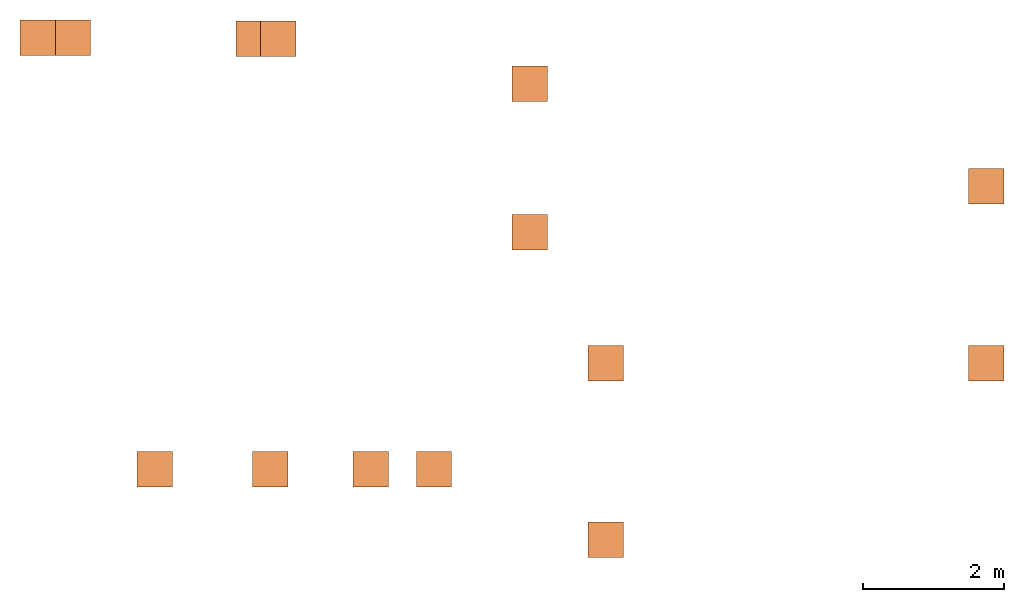
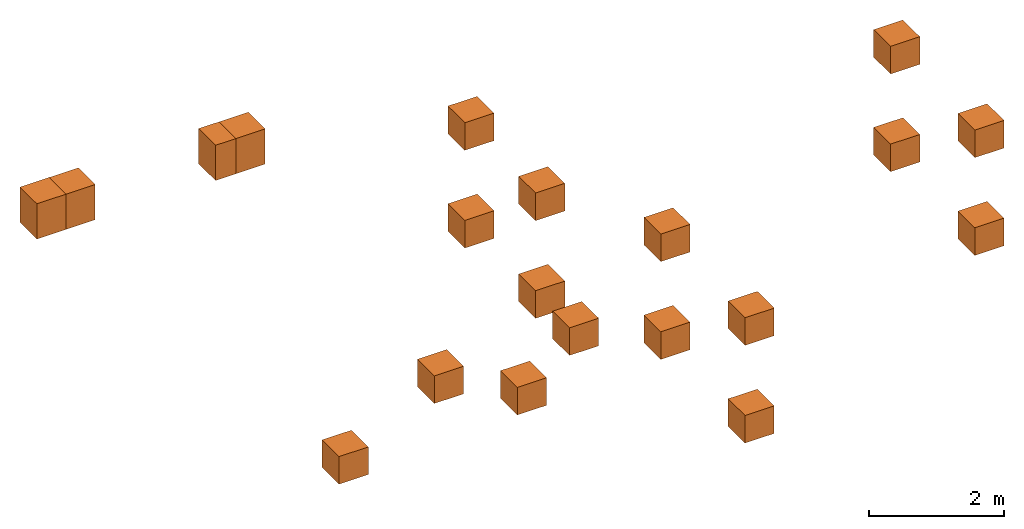
# One storey: 20 proxies.
"""IFC2X3 building model written with IfcOpenShell, lengths in metres."""

from ifc_helpers import new_model, entity, si_unit, converted_unit, frame, origin, place, context, subcontext, project, spatial, faceted_brep, material, element, save


model = new_model("IFC2X3")

# Units and contexts
model_context = context("Model", 3, precision=1e-05, world=origin())
body_context = subcontext(model_context, "Body", "Model", "MODEL_VIEW")
ifc_project = project(units=[si_unit("LENGTHUNIT", "METRE"), si_unit("AREAUNIT", "SQUARE_METRE"), si_unit("VOLUMEUNIT", "CUBIC_METRE"), converted_unit("PLANEANGLEUNIT", "DEGREE", entity("IfcPlaneAngleMeasure", 0.0174532925199433), si_unit("PLANEANGLEUNIT", "RADIAN"), dimensions=[0, 0, 0, 0, 0, 0, 0])], contexts=[model_context])

# Site, building, storey
site_placement = place(None, frame((2.0, 7.0, 6.0)))
site = spatial("IfcSite", under=ifc_project, at=site_placement, CompositionType="ELEMENT")
building_placement = place(site_placement, origin())
building = spatial("IfcBuilding", under=site, at=building_placement, Name="de", CompositionType="ELEMENT")
storey_placement = place(building_placement, frame((0.0, 0.0, 4.0)))
storey = spatial("IfcBuildingStorey", under=building, at=storey_placement, CompositionType="ELEMENT", Elevation=4.0)

# Proxies
ifc_material_1 = material()
proxy_1_placement = place(storey_placement, frame((-5.857044050769239, 7.518461170358987, 3.07)))
element("IfcBuildingElementProxy", 1, at=proxy_1_placement, inside=storey, material=ifc_material_1, context=body_context, shape_type="Brep", body=[
    faceted_brep([(0.0, 0.0, 0.0), (0.5, 0.0, 0.0), (0.5, 0.5, 0.0), (0.0, 0.5, 0.0), (0.5, 0.0, 0.6382133161913789), (0.0, 0.0, 0.6382133161913789), (0.0, 0.5, 0.6382133161913789), (0.5, 0.5, 0.6382133161913789), (0.5, 0.0, 0.0), (0.0, 0.0, 0.0), (0.0, 0.0, 0.6382133161913789), (0.5, 0.0, 0.6382133161913789), (0.5, 0.5, 0.0), (0.5, 0.0, 0.0), (0.5, 0.0, 0.6382133161913789), (0.5, 0.5, 0.6382133161913789), (0.0, 0.5, 0.0), (0.5, 0.5, 0.0), (0.5, 0.5, 0.6382133161913789), (0.0, 0.5, 0.6382133161913789), (0.0, 0.0, 0.0), (0.0, 0.5, 0.0), (0.0, 0.5, 0.6382133161913789), (0.0, 0.0, 0.6382133161913789)], [[[0, 1, 2, 3]], [[4, 5, 6, 7]], [[8, 9, 10, 11]], [[12, 13, 14, 15]], [[16, 17, 18, 19]], [[20, 21, 22, 23]]], orient=[[False], [False], [False], [False], [False], [False]]),
])
ifc_material_2 = material()
proxy_2_placement = place(storey_placement, frame((-5.357044050769239, 7.518461170358987, 3.07)))
element("IfcBuildingElementProxy", 2, at=proxy_2_placement, inside=storey, material=ifc_material_2, context=body_context, shape_type="Brep", body=[
    faceted_brep([(0.0, 0.0, 0.0), (0.5, 0.0, 0.0), (0.5, 0.5, 0.0), (0.0, 0.5, 0.0), (0.5, 0.0, 0.6382133161913789), (0.0, 0.0, 0.6382133161913789), (0.0, 0.5, 0.6382133161913789), (0.5, 0.5, 0.6382133161913789), (0.5, 0.0, 0.0), (0.0, 0.0, 0.0), (0.0, 0.0, 0.6382133161913789), (0.5, 0.0, 0.6382133161913789), (0.5, 0.5, 0.0), (0.5, 0.0, 0.0), (0.5, 0.0, 0.6382133161913789), (0.5, 0.5, 0.6382133161913789), (0.0, 0.5, 0.0), (0.5, 0.5, 0.0), (0.5, 0.5, 0.6382133161913789), (0.0, 0.5, 0.6382133161913789), (0.0, 0.0, 0.0), (0.0, 0.5, 0.0), (0.0, 0.5, 0.6382133161913789), (0.0, 0.0, 0.6382133161913789)], [[[0, 1, 2, 3]], [[4, 5, 6, 7]], [[8, 9, 10, 11]], [[12, 13, 14, 15]], [[16, 17, 18, 19]], [[20, 21, 22, 23]]], orient=[[False], [False], [False], [False], [False], [False]]),
])
ifc_material_3 = material()
proxy_3_placement = place(storey_placement, frame((-2.803355565197468, 7.504048402584867, 3.07)))
element("IfcBuildingElementProxy", 3, at=proxy_3_placement, inside=storey, material=ifc_material_3, context=body_context, shape_type="Brep", body=[
    faceted_brep([(0.0, 0.0, 0.0), (0.5, 0.0, 0.0), (0.5, 0.5, 0.0), (0.0, 0.5, 0.0), (0.5, 0.0, 0.6382133161913789), (0.0, 0.0, 0.6382133161913789), (0.0, 0.5, 0.6382133161913789), (0.5, 0.5, 0.6382133161913789), (0.5, 0.0, 0.0), (0.0, 0.0, 0.0), (0.0, 0.0, 0.6382133161913789), (0.5, 0.0, 0.6382133161913789), (0.5, 0.5, 0.0), (0.5, 0.0, 0.0), (0.5, 0.0, 0.6382133161913789), (0.5, 0.5, 0.6382133161913789), (0.0, 0.5, 0.0), (0.5, 0.5, 0.0), (0.5, 0.5, 0.6382133161913789), (0.0, 0.5, 0.6382133161913789), (0.0, 0.0, 0.0), (0.0, 0.5, 0.0), (0.0, 0.5, 0.6382133161913789), (0.0, 0.0, 0.6382133161913789)], [[[0, 1, 2, 3]], [[4, 5, 6, 7]], [[8, 9, 10, 11]], [[12, 13, 14, 15]], [[16, 17, 18, 19]], [[20, 21, 22, 23]]], orient=[[False], [False], [False], [False], [False], [False]]),
])
ifc_material_4 = material()
proxy_4_placement = place(storey_placement, frame((-2.454882605736548, 7.504048402584867, 3.07)))
element("IfcBuildingElementProxy", 4, at=proxy_4_placement, inside=storey, material=ifc_material_4, context=body_context, shape_type="Brep", body=[
    faceted_brep([(0.0, 0.0, 0.0), (0.5, 0.0, 0.0), (0.5, 0.5, 0.0), (0.0, 0.5, 0.0), (0.5, 0.0, 0.6382133161913789), (0.0, 0.0, 0.6382133161913789), (0.0, 0.5, 0.6382133161913789), (0.5, 0.5, 0.6382133161913789), (0.5, 0.0, 0.0), (0.0, 0.0, 0.0), (0.0, 0.0, 0.6382133161913789), (0.5, 0.0, 0.6382133161913789), (0.5, 0.5, 0.0), (0.5, 0.0, 0.0), (0.5, 0.0, 0.6382133161913789), (0.5, 0.5, 0.6382133161913789), (0.0, 0.5, 0.0), (0.5, 0.5, 0.0), (0.5, 0.5, 0.6382133161913789), (0.0, 0.5, 0.6382133161913789), (0.0, 0.0, 0.0), (0.0, 0.5, 0.0), (0.0, 0.5, 0.6382133161913789), (0.0, 0.0, 0.6382133161913789)], [[[0, 1, 2, 3]], [[4, 5, 6, 7]], [[8, 9, 10, 11]], [[12, 13, 14, 15]], [[16, 17, 18, 19]], [[20, 21, 22, 23]]], orient=[[False], [False], [False], [False], [False], [False]]),
])
ifc_material_5 = material()
proxy_5_placement = place(storey_placement, frame((-4.2015625, 1.416979166666668, 1.75)))
element("IfcBuildingElementProxy", 5, at=proxy_5_placement, inside=storey, material=ifc_material_5, context=body_context, shape_type="Brep", body=[
    faceted_brep([(0.0, 0.5, 0.0), (0.5, 0.5, 0.0), (0.5, 0.5, 0.5), (0.0, 0.5, 0.5), (0.5, 0.0, 0.0), (0.0, 0.0, 0.0), (0.0, 0.0, 0.5), (0.5, 0.0, 0.5), (0.5, 0.5, 0.0), (0.0, 0.5, 0.0), (0.0, 0.0, 0.0), (0.5, 0.0, 0.0), (0.5, 0.5, 0.5), (0.5, 0.5, 0.0), (0.5, 0.0, 0.0), (0.5, 0.0, 0.5), (0.0, 0.5, 0.5), (0.5, 0.5, 0.5), (0.5, 0.0, 0.5), (0.0, 0.0, 0.5), (0.0, 0.5, 0.0), (0.0, 0.5, 0.5), (0.0, 0.0, 0.5), (0.0, 0.0, 0.0)], [[[0, 1, 2, 3]], [[4, 5, 6, 7]], [[8, 9, 10, 11]], [[12, 13, 14, 15]], [[16, 17, 18, 19]], [[20, 21, 22, 23]]], orient=[[False], [False], [False], [False], [False], [False]]),
])
ifc_material_6 = material()
proxy_6_placement = place(storey_placement, frame((-1.147874014428229, 1.416979166666668, 1.934412767774121)))
element("IfcBuildingElementProxy", 6, at=proxy_6_placement, inside=storey, material=ifc_material_6, context=body_context, shape_type="Brep", body=[
    faceted_brep([(0.0, 0.5, 0.0), (0.5, 0.5, 0.0), (0.5, 0.5, 0.5), (0.0, 0.5, 0.5), (0.5, 0.0, 0.0), (0.0, 0.0, 0.0), (0.0, 0.0, 0.5), (0.5, 0.0, 0.5), (0.5, 0.5, 0.0), (0.0, 0.5, 0.0), (0.0, 0.0, 0.0), (0.5, 0.0, 0.0), (0.5, 0.5, 0.5), (0.5, 0.5, 0.0), (0.5, 0.0, 0.0), (0.5, 0.0, 0.5), (0.0, 0.5, 0.5), (0.5, 0.5, 0.5), (0.5, 0.0, 0.5), (0.0, 0.0, 0.5), (0.0, 0.5, 0.0), (0.0, 0.5, 0.5), (0.0, 0.0, 0.5), (0.0, 0.0, 0.0)], [[[0, 1, 2, 3]], [[4, 5, 6, 7]], [[8, 9, 10, 11]], [[12, 13, 14, 15]], [[16, 17, 18, 19]], [[20, 21, 22, 23]]], orient=[[False], [False], [False], [False], [False], [False]]),
])
ifc_material_7 = material()
proxy_7_placement = place(storey_placement, frame((-2.569125779134114, 1.416979166666668, 2.640069238362357)))
element("IfcBuildingElementProxy", 7, at=proxy_7_placement, inside=storey, material=ifc_material_7, context=body_context, shape_type="Brep", body=[
    faceted_brep([(0.0, 0.5, 0.0), (0.5, 0.5, 0.0), (0.5, 0.5, 0.5), (0.0, 0.5, 0.5), (0.5, 0.0, 0.0), (0.0, 0.0, 0.0), (0.0, 0.0, 0.5), (0.5, 0.0, 0.5), (0.5, 0.5, 0.0), (0.0, 0.5, 0.0), (0.0, 0.0, 0.0), (0.5, 0.0, 0.0), (0.5, 0.5, 0.5), (0.5, 0.5, 0.0), (0.5, 0.0, 0.0), (0.5, 0.0, 0.5), (0.0, 0.5, 0.5), (0.5, 0.5, 0.5), (0.5, 0.0, 0.5), (0.0, 0.0, 0.5), (0.0, 0.5, 0.0), (0.0, 0.5, 0.5), (0.0, 0.0, 0.5), (0.0, 0.0, 0.0)], [[[0, 1, 2, 3]], [[4, 5, 6, 7]], [[8, 9, 10, 11]], [[12, 13, 14, 15]], [[16, 17, 18, 19]], [[20, 21, 22, 23]]], orient=[[False], [False], [False], [False], [False], [False]]),
])
ifc_material_8 = material()
proxy_8_placement = place(storey_placement, frame((-0.253379896781169, 1.416979166666668, 2.699702179538829)))
element("IfcBuildingElementProxy", 8, at=proxy_8_placement, inside=storey, material=ifc_material_8, context=body_context, shape_type="Brep", body=[
    faceted_brep([(0.0, 0.5, 0.0), (0.5, 0.5, 0.0), (0.5, 0.5, 0.5), (0.0, 0.5, 0.5), (0.5, 0.0, 0.0), (0.0, 0.0, 0.0), (0.0, 0.0, 0.5), (0.5, 0.0, 0.5), (0.5, 0.5, 0.0), (0.0, 0.5, 0.0), (0.0, 0.0, 0.0), (0.5, 0.0, 0.0), (0.5, 0.5, 0.5), (0.5, 0.5, 0.0), (0.5, 0.0, 0.0), (0.5, 0.0, 0.5), (0.0, 0.5, 0.5), (0.5, 0.5, 0.5), (0.5, 0.0, 0.5), (0.0, 0.0, 0.5), (0.0, 0.5, 0.0), (0.0, 0.5, 0.5), (0.0, 0.0, 0.5), (0.0, 0.0, 0.0)], [[[0, 1, 2, 3]], [[4, 5, 6, 7]], [[8, 9, 10, 11]], [[12, 13, 14, 15]], [[16, 17, 18, 19]], [[20, 21, 22, 23]]], orient=[[False], [False], [False], [False], [False], [False]]),
])
ifc_material_9 = material()
proxy_9_placement = place(storey_placement, frame((2.176390691454128, 2.916979166666668, 2.638089238362359)))
element("IfcBuildingElementProxy", 9, at=proxy_9_placement, inside=storey, material=ifc_material_9, context=body_context, shape_type="Brep", body=[
    faceted_brep([(0.0, 0.5, 0.0), (0.5, 0.5, 0.0), (0.5, 0.5, 0.5), (0.0, 0.5, 0.5), (0.5, 0.0, 0.0), (0.0, 0.0, 0.0), (0.0, 0.0, 0.5), (0.5, 0.0, 0.5), (0.5, 0.5, 0.0), (0.0, 0.5, 0.0), (0.0, 0.0, 0.0), (0.5, 0.0, 0.0), (0.5, 0.5, 0.5), (0.5, 0.5, 0.0), (0.5, 0.0, 0.0), (0.5, 0.0, 0.5), (0.0, 0.5, 0.5), (0.5, 0.5, 0.5), (0.5, 0.0, 0.5), (0.0, 0.0, 0.5), (0.0, 0.5, 0.0), (0.0, 0.5, 0.5), (0.0, 0.0, 0.5), (0.0, 0.0, 0.0)], [[[0, 1, 2, 3]], [[4, 5, 6, 7]], [[8, 9, 10, 11]], [[12, 13, 14, 15]], [[16, 17, 18, 19]], [[20, 21, 22, 23]]], orient=[[False], [False], [False], [False], [False], [False]]),
])
ifc_material_10 = material()
proxy_10_placement = place(storey_placement, frame((2.176390691454128, 2.916979166666668, 0.8680892383623586)))
element("IfcBuildingElementProxy", 10, at=proxy_10_placement, inside=storey, material=ifc_material_10, context=body_context, shape_type="Brep", body=[
    faceted_brep([(0.0, 0.5, 0.0), (0.5, 0.5, 0.0), (0.5, 0.5, 0.5), (0.0, 0.5, 0.5), (0.5, 0.0, 0.0), (0.0, 0.0, 0.0), (0.0, 0.0, 0.5), (0.5, 0.0, 0.5), (0.5, 0.5, 0.0), (0.0, 0.5, 0.0), (0.0, 0.0, 0.0), (0.5, 0.0, 0.0), (0.5, 0.5, 0.5), (0.5, 0.5, 0.0), (0.5, 0.0, 0.0), (0.5, 0.0, 0.5), (0.0, 0.5, 0.5), (0.5, 0.5, 0.5), (0.5, 0.0, 0.5), (0.0, 0.0, 0.5), (0.0, 0.5, 0.0), (0.0, 0.5, 0.5), (0.0, 0.0, 0.5), (0.0, 0.0, 0.0)], [[[0, 1, 2, 3]], [[4, 5, 6, 7]], [[8, 9, 10, 11]], [[12, 13, 14, 15]], [[16, 17, 18, 19]], [[20, 21, 22, 23]]], orient=[[False], [False], [False], [False], [False], [False]]),
])
ifc_material_11 = material()
proxy_11_placement = place(storey_placement, frame((2.176390691454128, 0.4169791666666679, 2.638089238362359)))
element("IfcBuildingElementProxy", 11, at=proxy_11_placement, inside=storey, material=ifc_material_11, context=body_context, shape_type="Brep", body=[
    faceted_brep([(0.0, 0.5, 0.0), (0.5, 0.5, 0.0), (0.5, 0.5, 0.5), (0.0, 0.5, 0.5), (0.5, 0.0, 0.0), (0.0, 0.0, 0.0), (0.0, 0.0, 0.5), (0.5, 0.0, 0.5), (0.5, 0.5, 0.0), (0.0, 0.5, 0.0), (0.0, 0.0, 0.0), (0.5, 0.0, 0.0), (0.5, 0.5, 0.5), (0.5, 0.5, 0.0), (0.5, 0.0, 0.0), (0.5, 0.0, 0.5), (0.0, 0.5, 0.5), (0.5, 0.5, 0.5), (0.5, 0.0, 0.5), (0.0, 0.0, 0.5), (0.0, 0.5, 0.0), (0.0, 0.5, 0.5), (0.0, 0.0, 0.5), (0.0, 0.0, 0.0)], [[[0, 1, 2, 3]], [[4, 5, 6, 7]], [[8, 9, 10, 11]], [[12, 13, 14, 15]], [[16, 17, 18, 19]], [[20, 21, 22, 23]]], orient=[[False], [False], [False], [False], [False], [False]]),
])
ifc_material_12 = material()
proxy_12_placement = place(storey_placement, frame((2.176390691454128, 0.4169791666666679, 0.8680892383623586)))
element("IfcBuildingElementProxy", 12, at=proxy_12_placement, inside=storey, material=ifc_material_12, context=body_context, shape_type="Brep", body=[
    faceted_brep([(0.0, 0.5, 0.0), (0.5, 0.5, 0.0), (0.5, 0.5, 0.5), (0.0, 0.5, 0.5), (0.5, 0.0, 0.0), (0.0, 0.0, 0.0), (0.0, 0.0, 0.5), (0.5, 0.0, 0.5), (0.5, 0.5, 0.0), (0.0, 0.5, 0.0), (0.0, 0.0, 0.0), (0.5, 0.0, 0.0), (0.5, 0.5, 0.5), (0.5, 0.5, 0.0), (0.5, 0.0, 0.0), (0.5, 0.0, 0.5), (0.0, 0.5, 0.5), (0.5, 0.5, 0.5), (0.5, 0.0, 0.5), (0.0, 0.0, 0.5), (0.0, 0.5, 0.0), (0.0, 0.5, 0.5), (0.0, 0.0, 0.5), (0.0, 0.0, 0.0)], [[[0, 1, 2, 3]], [[4, 5, 6, 7]], [[8, 9, 10, 11]], [[12, 13, 14, 15]], [[16, 17, 18, 19]], [[20, 21, 22, 23]]], orient=[[False], [False], [False], [False], [False], [False]]),
])
ifc_material_13 = material()
proxy_13_placement = place(storey_placement, frame((7.556510837974278, 5.416979166666665, 2.638089238362359)))
element("IfcBuildingElementProxy", 13, at=proxy_13_placement, inside=storey, material=ifc_material_13, context=body_context, shape_type="Brep", body=[
    faceted_brep([(0.0, 0.5, 0.0), (0.5, 0.5, 0.0), (0.5, 0.5, 0.5), (0.0, 0.5, 0.5), (0.5, 0.0, 0.0), (0.0, 0.0, 0.0), (0.0, 0.0, 0.5), (0.5, 0.0, 0.5), (0.5, 0.5, 0.0), (0.0, 0.5, 0.0), (0.0, 0.0, 0.0), (0.5, 0.0, 0.0), (0.5, 0.5, 0.5), (0.5, 0.5, 0.0), (0.5, 0.0, 0.0), (0.5, 0.0, 0.5), (0.0, 0.5, 0.5), (0.5, 0.5, 0.5), (0.5, 0.0, 0.5), (0.0, 0.0, 0.5), (0.0, 0.5, 0.0), (0.0, 0.5, 0.5), (0.0, 0.0, 0.5), (0.0, 0.0, 0.0)], [[[0, 1, 2, 3]], [[4, 5, 6, 7]], [[8, 9, 10, 11]], [[12, 13, 14, 15]], [[16, 17, 18, 19]], [[20, 21, 22, 23]]], orient=[[False], [False], [False], [False], [False], [False]]),
])
ifc_material_14 = material()
proxy_14_placement = place(storey_placement, frame((7.556510837974278, 5.416979166666665, 0.8680892383623586)))
element("IfcBuildingElementProxy", 14, at=proxy_14_placement, inside=storey, material=ifc_material_14, context=body_context, shape_type="Brep", body=[
    faceted_brep([(0.0, 0.5, 0.0), (0.5, 0.5, 0.0), (0.5, 0.5, 0.5), (0.0, 0.5, 0.5), (0.5, 0.0, 0.0), (0.0, 0.0, 0.0), (0.0, 0.0, 0.5), (0.5, 0.0, 0.5), (0.5, 0.5, 0.0), (0.0, 0.5, 0.0), (0.0, 0.0, 0.0), (0.5, 0.0, 0.0), (0.5, 0.5, 0.5), (0.5, 0.5, 0.0), (0.5, 0.0, 0.0), (0.5, 0.0, 0.5), (0.0, 0.5, 0.5), (0.5, 0.5, 0.5), (0.5, 0.0, 0.5), (0.0, 0.0, 0.5), (0.0, 0.5, 0.0), (0.0, 0.5, 0.5), (0.0, 0.0, 0.5), (0.0, 0.0, 0.0)], [[[0, 1, 2, 3]], [[4, 5, 6, 7]], [[8, 9, 10, 11]], [[12, 13, 14, 15]], [[16, 17, 18, 19]], [[20, 21, 22, 23]]], orient=[[False], [False], [False], [False], [False], [False]]),
])
ifc_material_15 = material()
proxy_15_placement = place(storey_placement, frame((7.556510837974278, 2.916979166666665, 2.638089238362359)))
element("IfcBuildingElementProxy", 15, at=proxy_15_placement, inside=storey, material=ifc_material_15, context=body_context, shape_type="Brep", body=[
    faceted_brep([(0.0, 0.5, 0.0), (0.5, 0.5, 0.0), (0.5, 0.5, 0.5), (0.0, 0.5, 0.5), (0.5, 0.0, 0.0), (0.0, 0.0, 0.0), (0.0, 0.0, 0.5), (0.5, 0.0, 0.5), (0.5, 0.5, 0.0), (0.0, 0.5, 0.0), (0.0, 0.0, 0.0), (0.5, 0.0, 0.0), (0.5, 0.5, 0.5), (0.5, 0.5, 0.0), (0.5, 0.0, 0.0), (0.5, 0.0, 0.5), (0.0, 0.5, 0.5), (0.5, 0.5, 0.5), (0.5, 0.0, 0.5), (0.0, 0.0, 0.5), (0.0, 0.5, 0.0), (0.0, 0.5, 0.5), (0.0, 0.0, 0.5), (0.0, 0.0, 0.0)], [[[0, 1, 2, 3]], [[4, 5, 6, 7]], [[8, 9, 10, 11]], [[12, 13, 14, 15]], [[16, 17, 18, 19]], [[20, 21, 22, 23]]], orient=[[False], [False], [False], [False], [False], [False]]),
])
ifc_material_16 = material()
proxy_16_placement = place(storey_placement, frame((7.556510837974278, 2.916979166666665, 0.8680892383623586)))
element("IfcBuildingElementProxy", 16, at=proxy_16_placement, inside=storey, material=ifc_material_16, context=body_context, shape_type="Brep", body=[
    faceted_brep([(0.0, 0.5, 0.0), (0.5, 0.5, 0.0), (0.5, 0.5, 0.5), (0.0, 0.5, 0.5), (0.5, 0.0, 0.0), (0.0, 0.0, 0.0), (0.0, 0.0, 0.5), (0.5, 0.0, 0.5), (0.5, 0.5, 0.0), (0.0, 0.5, 0.0), (0.0, 0.0, 0.0), (0.5, 0.0, 0.0), (0.5, 0.5, 0.5), (0.5, 0.5, 0.0), (0.5, 0.0, 0.0), (0.5, 0.0, 0.5), (0.0, 0.5, 0.5), (0.5, 0.5, 0.5), (0.5, 0.0, 0.5), (0.0, 0.0, 0.5), (0.0, 0.5, 0.0), (0.0, 0.5, 0.5), (0.0, 0.0, 0.5), (0.0, 0.0, 0.0)], [[[0, 1, 2, 3]], [[4, 5, 6, 7]], [[8, 9, 10, 11]], [[12, 13, 14, 15]], [[16, 17, 18, 19]], [[20, 21, 22, 23]]], orient=[[False], [False], [False], [False], [False], [False]]),
])
ifc_material_17 = material()
proxy_17_placement = place(storey_placement, frame((1.098437499999998, 6.865484249084253, 2.638089238362359)))
element("IfcBuildingElementProxy", 17, at=proxy_17_placement, inside=storey, material=ifc_material_17, context=body_context, shape_type="Brep", body=[
    faceted_brep([(0.0, 0.5, 0.0), (0.5, 0.5, 0.0), (0.5, 0.5, 0.5), (0.0, 0.5, 0.5), (0.5, 0.0, 0.0), (0.0, 0.0, 0.0), (0.0, 0.0, 0.5), (0.5, 0.0, 0.5), (0.5, 0.5, 0.0), (0.0, 0.5, 0.0), (0.0, 0.0, 0.0), (0.5, 0.0, 0.0), (0.5, 0.5, 0.5), (0.5, 0.5, 0.0), (0.5, 0.0, 0.0), (0.5, 0.0, 0.5), (0.0, 0.5, 0.5), (0.5, 0.5, 0.5), (0.5, 0.0, 0.5), (0.0, 0.0, 0.5), (0.0, 0.5, 0.0), (0.0, 0.5, 0.5), (0.0, 0.0, 0.5), (0.0, 0.0, 0.0)], [[[0, 1, 2, 3]], [[4, 5, 6, 7]], [[8, 9, 10, 11]], [[12, 13, 14, 15]], [[16, 17, 18, 19]], [[20, 21, 22, 23]]], orient=[[False], [False], [False], [False], [False], [False]]),
])
ifc_material_18 = material()
proxy_18_placement = place(storey_placement, frame((1.098437499999998, 6.865484249084253, 0.8680892383623586)))
element("IfcBuildingElementProxy", 18, at=proxy_18_placement, inside=storey, material=ifc_material_18, context=body_context, shape_type="Brep", body=[
    faceted_brep([(0.0, 0.5, 0.0), (0.5, 0.5, 0.0), (0.5, 0.5, 0.5), (0.0, 0.5, 0.5), (0.5, 0.0, 0.0), (0.0, 0.0, 0.0), (0.0, 0.0, 0.5), (0.5, 0.0, 0.5), (0.5, 0.5, 0.0), (0.0, 0.5, 0.0), (0.0, 0.0, 0.0), (0.5, 0.0, 0.0), (0.5, 0.5, 0.5), (0.5, 0.5, 0.0), (0.5, 0.0, 0.0), (0.5, 0.0, 0.5), (0.0, 0.5, 0.5), (0.5, 0.5, 0.5), (0.5, 0.0, 0.5), (0.0, 0.0, 0.5), (0.0, 0.5, 0.0), (0.0, 0.5, 0.5), (0.0, 0.0, 0.5), (0.0, 0.0, 0.0)], [[[0, 1, 2, 3]], [[4, 5, 6, 7]], [[8, 9, 10, 11]], [[12, 13, 14, 15]], [[16, 17, 18, 19]], [[20, 21, 22, 23]]], orient=[[False], [False], [False], [False], [False], [False]]),
])
ifc_material_19 = material()
proxy_19_placement = place(storey_placement, frame((1.0984375, 4.765484249084255, 2.638089238362359)))
element("IfcBuildingElementProxy", 19, at=proxy_19_placement, inside=storey, material=ifc_material_19, context=body_context, shape_type="Brep", body=[
    faceted_brep([(0.0, 0.5, 0.0), (0.5, 0.5, 0.0), (0.5, 0.5, 0.5), (0.0, 0.5, 0.5), (0.5, 0.0, 0.0), (0.0, 0.0, 0.0), (0.0, 0.0, 0.5), (0.5, 0.0, 0.5), (0.5, 0.5, 0.0), (0.0, 0.5, 0.0), (0.0, 0.0, 0.0), (0.5, 0.0, 0.0), (0.5, 0.5, 0.5), (0.5, 0.5, 0.0), (0.5, 0.0, 0.0), (0.5, 0.0, 0.5), (0.0, 0.5, 0.5), (0.5, 0.5, 0.5), (0.5, 0.0, 0.5), (0.0, 0.0, 0.5), (0.0, 0.5, 0.0), (0.0, 0.5, 0.5), (0.0, 0.0, 0.5), (0.0, 0.0, 0.0)], [[[0, 1, 2, 3]], [[4, 5, 6, 7]], [[8, 9, 10, 11]], [[12, 13, 14, 15]], [[16, 17, 18, 19]], [[20, 21, 22, 23]]], orient=[[False], [False], [False], [False], [False], [False]]),
])
ifc_material_20 = material()
proxy_20_placement = place(storey_placement, frame((1.0984375, 4.765484249084255, 0.8680892383623586)))
element("IfcBuildingElementProxy", 20, at=proxy_20_placement, inside=storey, material=ifc_material_20, context=body_context, shape_type="Brep", body=[
    faceted_brep([(0.0, 0.5, 0.0), (0.5, 0.5, 0.0), (0.5, 0.5, 0.5), (0.0, 0.5, 0.5), (0.5, 0.0, 0.0), (0.0, 0.0, 0.0), (0.0, 0.0, 0.5), (0.5, 0.0, 0.5), (0.5, 0.5, 0.0), (0.0, 0.5, 0.0), (0.0, 0.0, 0.0), (0.5, 0.0, 0.0), (0.5, 0.5, 0.5), (0.5, 0.5, 0.0), (0.5, 0.0, 0.0), (0.5, 0.0, 0.5), (0.0, 0.5, 0.5), (0.5, 0.5, 0.5), (0.5, 0.0, 0.5), (0.0, 0.0, 0.5), (0.0, 0.5, 0.0), (0.0, 0.5, 0.5), (0.0, 0.0, 0.5), (0.0, 0.0, 0.0)], [[[0, 1, 2, 3]], [[4, 5, 6, 7]], [[8, 9, 10, 11]], [[12, 13, 14, 15]], [[16, 17, 18, 19]], [[20, 21, 22, 23]]], orient=[[False], [False], [False], [False], [False], [False]]),
])

save(model, "model.ifc")
